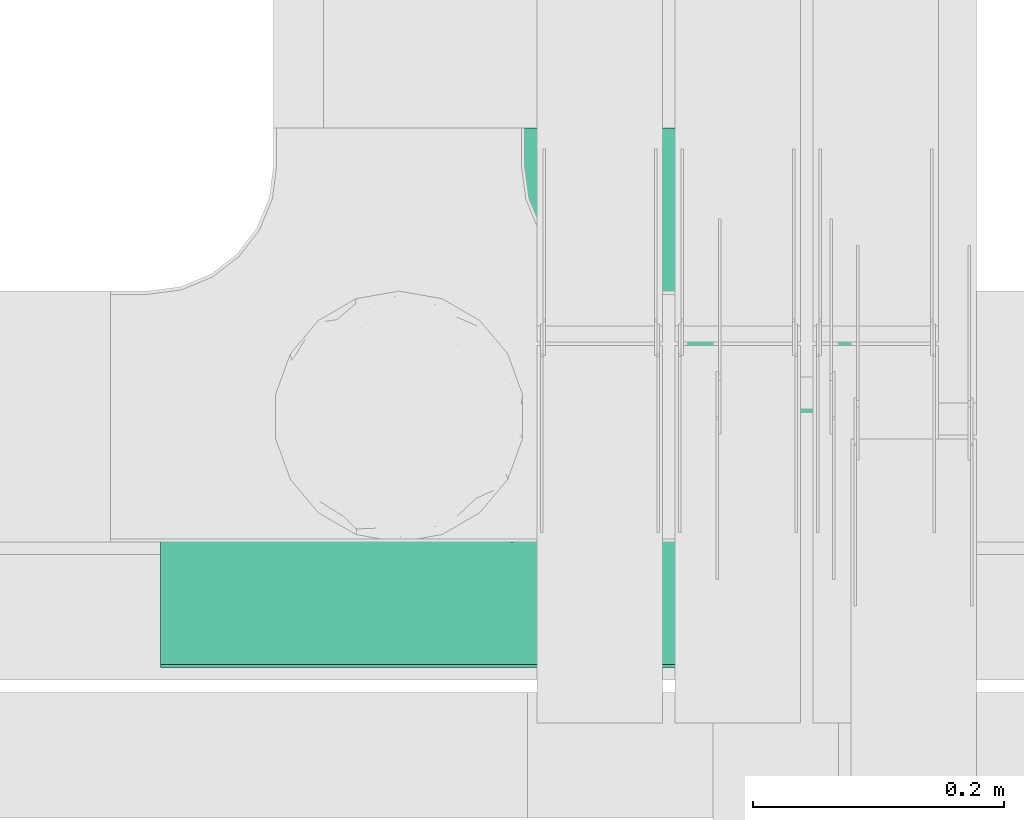
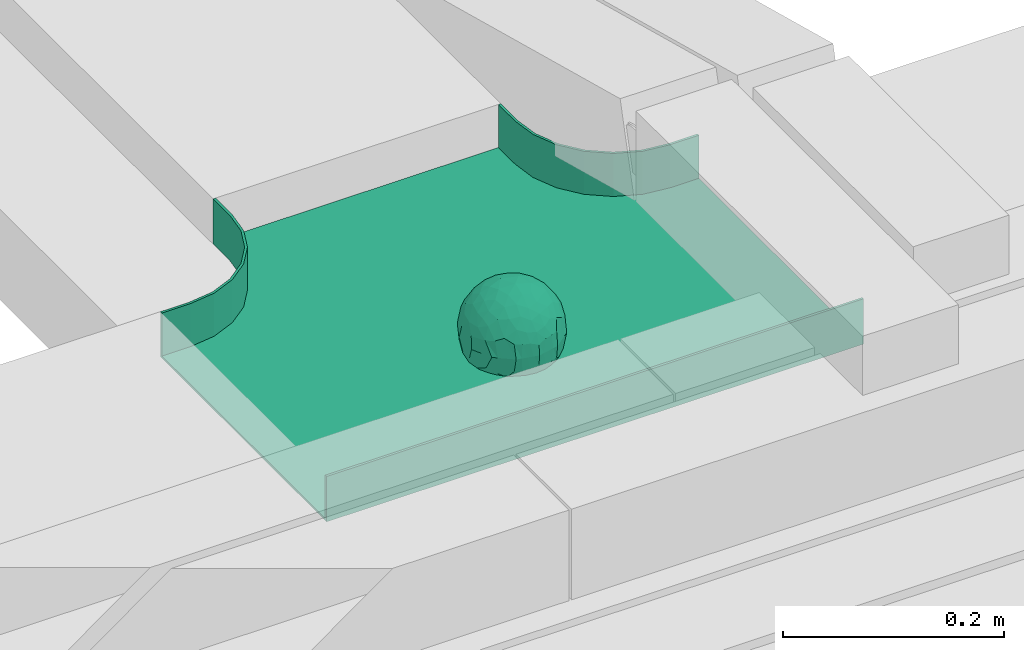
# One storey, part 32 of 32: 1 flow fitting.
"""IFC2X3 building model written with IfcOpenShell, lengths in millimetres."""

from ifc_helpers import new_model, entity, si_unit, converted_unit, derived_unit, direction, frame, origin, place, context, subcontext, project, spatial, faceted_brep, source, transform, mapped, material, material_list, type_object, type_shapes, element, save


model = new_model("IFC2X3")

# Units and contexts
model_context = context("Model", 3, precision=0.01, world=origin(), true_north=direction((6.12303176911189e-17, 1.0)))
body_context = subcontext(model_context, "Body", "Model", "MODEL_VIEW")
ifc_project = project(units=[si_unit("LENGTHUNIT", "METRE", prefix="MILLI"), si_unit("AREAUNIT", "SQUARE_METRE"), si_unit("VOLUMEUNIT", "CUBIC_METRE"), converted_unit("PLANEANGLEUNIT", "DEGREE", entity("IfcRatioMeasure", 0.0174532925199433), si_unit("PLANEANGLEUNIT", "RADIAN"), dimensions=[0, 0, 0, 0, 0, 0, 0]), si_unit("MASSUNIT", "GRAM", prefix="KILO"), derived_unit("MASSDENSITYUNIT", [(si_unit("MASSUNIT", "GRAM", prefix="KILO"), 1), (si_unit("LENGTHUNIT", "METRE"), -3)]), derived_unit("MOMENTOFINERTIAUNIT", [(si_unit("LENGTHUNIT", "METRE"), 4)]), si_unit("TIMEUNIT", "SECOND"), si_unit("FREQUENCYUNIT", "HERTZ"), si_unit("THERMODYNAMICTEMPERATUREUNIT", "DEGREE_CELSIUS"), derived_unit("THERMALTRANSMITTANCEUNIT", [(si_unit("MASSUNIT", "GRAM", prefix="KILO"), 1), (si_unit("THERMODYNAMICTEMPERATUREUNIT", "KELVIN"), -1), (si_unit("TIMEUNIT", "SECOND"), -3)]), derived_unit("VOLUMETRICFLOWRATEUNIT", [(si_unit("LENGTHUNIT", "METRE"), 3), (si_unit("TIMEUNIT", "SECOND"), -1)]), derived_unit("MASSFLOWRATEUNIT", [(si_unit("MASSUNIT", "GRAM", prefix="KILO"), 1), (si_unit("TIMEUNIT", "SECOND"), -1)]), derived_unit("ROTATIONALFREQUENCYUNIT", [(si_unit("TIMEUNIT", "SECOND"), -1)]), si_unit("ELECTRICCURRENTUNIT", "AMPERE"), si_unit("ELECTRICVOLTAGEUNIT", "VOLT"), si_unit("POWERUNIT", "WATT"), si_unit("FORCEUNIT", "NEWTON", prefix="KILO"), si_unit("ILLUMINANCEUNIT", "LUX"), si_unit("LUMINOUSFLUXUNIT", "LUMEN"), si_unit("LUMINOUSINTENSITYUNIT", "CANDELA"), derived_unit("USERDEFINED", [(si_unit("MASSUNIT", "GRAM", prefix="KILO"), -1), (si_unit("LENGTHUNIT", "METRE"), -2), (si_unit("TIMEUNIT", "SECOND"), 3), (si_unit("LUMINOUSFLUXUNIT", "LUMEN"), 1)]), derived_unit("LINEARVELOCITYUNIT", [(si_unit("LENGTHUNIT", "METRE"), 1), (si_unit("TIMEUNIT", "SECOND"), -1)]), si_unit("PRESSUREUNIT", "PASCAL"), derived_unit("USERDEFINED", [(si_unit("LENGTHUNIT", "METRE"), -2), (si_unit("MASSUNIT", "GRAM", prefix="KILO"), 1), (si_unit("TIMEUNIT", "SECOND"), -2)]), derived_unit("LINEARFORCEUNIT", [(si_unit("MASSUNIT", "GRAM", prefix="KILO"), 1), (si_unit("LENGTHUNIT", "METRE"), 1), (si_unit("TIMEUNIT", "SECOND"), -2), (si_unit("LENGTHUNIT", "METRE"), -1)]), derived_unit("PLANARFORCEUNIT", [(si_unit("MASSUNIT", "GRAM", prefix="KILO"), 1), (si_unit("LENGTHUNIT", "METRE"), 1), (si_unit("TIMEUNIT", "SECOND"), -2), (si_unit("LENGTHUNIT", "METRE"), -2)])], contexts=[model_context])

# Site, building, storey
site_placement = place(None, origin())
site = spatial("IfcSite", under=ifc_project, at=site_placement, CompositionType="ELEMENT")
building_placement = place(site_placement, origin())
building = spatial("IfcBuilding", under=site, at=building_placement, CompositionType="ELEMENT")
storey_placement = place(building_placement, frame((0.0, 0.0, 8100.0)))
storey = spatial("IfcBuildingStorey", under=building, at=storey_placement, CompositionType="ELEMENT", Elevation=8100.0)

# Flow fitting
ifc_material_1 = material()
ifc_material_2 = material()
ifc_material_list = material_list([ifc_material_1, ifc_material_2])
cable_carrier_fitting_type = type_object("IfcCableCarrierFittingType", PredefinedType="NOTDEFINED", material=ifc_material_1)
shared_shape = source(origin(), body_context, "Body", "Brep", [
    faceted_brep([(43.65, -13.62, -20.22), (44.77, 0.0, -22.26), (48.26, -5.6, -11.81), (16.66, 5.33, -46.84), (11.56, -8.33, -47.93), (2.02, 2.7, -49.89), (-7.81, -35.95, -33.86), (-17.21, -38.27, -27.19), (-11.13, -27.32, -40.37), (37.7, -7.25, -32.03), (10.64, 26.52, -41.03), (19.21, 19.84, -41.68), (10.42, 17.81, -45.54), (48.75, 0.0, 0.0), (48.07, 6.52, -12.13), (-37.46, 12.16, -30.81), (-31.35, 12.15, -37.01), (-38.09, 3.52, -32.2), (48.75, 11.13, 0.0), (9.67, 42.57, -24.39), (17.48, 37.97, -27.43), (8.35, 35.36, -34.35), (36.7, 20.43, -27.12), (28.22, 12.58, -39.31), (28.4, 24.01, -33.43), (37.1, 7.75, -32.61), (30.39, 38.11, 0.0), (34.74, 34.64, 0.0), (32.94, 32.13, -19.56), (26.04, 41.58, 0.0), (-44.77, 0.0, -22.26), (-35.92, -8.72, -33.67), (-42.7, -12.19, -22.99), (5.42, -48.76, 0.0), (0.0, -48.78, -10.96), (7.59, -47.43, -13.88), (34.0, -31.65, -18.51), (40.01, -26.24, -14.51), (30.39, -38.11, 0.0), (-47.55, -8.65, -12.8), (43.92, -21.15, 0.0), (-47.55, 8.68, -12.81), (-43.92, 21.15, 0.0), (-41.56, 23.54, -14.78), (-36.7, 20.43, -27.12), (-42.68, 12.16, -23.03), (-0.04, -44.68, -22.44), (43.35, 13.13, -21.19), (-9.67, -42.82, -23.94), (2.93, -38.3, -32.0), (10.58, -32.36, -36.62), (17.48, -37.97, -27.43), (29.42, -14.29, -37.82), (29.26, 0.0, -40.54), (-34.74, 34.64, 0.0), (-35.59, 30.87, -16.74), (16.27, 46.29, 0.0), (15.4, 45.37, -14.3), (10.85, 47.52, 0.0), (-22.09, 42.26, -15.04), (-16.27, 46.29, 0.0), (-15.4, 45.37, -14.3), (-35.57, -30.88, -16.76), (-34.74, -34.64, 0.0), (-41.54, -23.57, -14.78), (-21.2, -29.91, -34.0), (-22.09, -42.26, -15.04), (-28.59, -35.77, -20.07), (27.97, -26.92, -31.51), (26.56, -36.75, -21.06), (-4.7, -12.82, -48.1), (-3.71, -22.05, -44.72), (0.0, -29.85, -40.11), (-8.78, 23.47, -43.27), (-10.71, 12.15, -47.3), (-19.19, 19.81, -41.71), (19.21, -19.84, -41.68), (10.27, -43.25, -22.88), (-16.27, -46.29, 0.0), (-15.42, -45.43, -14.08), (-10.85, -47.52, 0.0), (-21.69, -45.05, 0.0), (-26.04, -41.58, 0.0), (-30.39, -38.11, 0.0), (-26.91, -11.71, -40.48), (-28.57, -22.53, -34.29), (-14.35, 0.55, -47.89), (20.39, 29.7, -34.67), (25.88, 35.56, -23.78), (-1.9, 38.3, -32.09), (-0.04, 44.68, -22.44), (-9.54, 42.67, -24.26), (-10.12, 33.04, -36.14), (-17.21, 38.27, -27.19), (-28.59, 35.77, -20.07), (-30.39, 38.11, 0.0), (-26.04, 41.58, 0.0), (-21.69, 45.05, 0.0), (0.92, 16.99, -47.01), (0.0, 29.85, -40.11), (-28.43, 23.64, -33.66), (22.08, -42.72, -13.7), (0.0, -50.0, 0.0), (-7.98, 47.29, -14.15), (-10.85, 47.52, 0.0), (-5.42, 48.76, 0.0), (-39.09, -31.17, 0.0), (-36.7, -20.43, -27.12), (-20.05, 29.88, -34.71), (48.75, -11.13, 0.0), (36.7, -20.43, -27.12), (39.09, -31.17, 0.0), (43.92, 21.15, 0.0), (41.04, 24.48, -14.72), (21.43, -9.87, -44.08), (19.85, -30.3, -34.47), (26.04, -41.58, 0.0), (8.28, -22.62, -43.82), (-19.19, -19.81, -41.71), (-17.56, -9.66, -45.81), (-29.26, 0.0, -40.54), (-22.28, 8.45, -43.96), (21.69, -45.05, 0.0), (-7.75, -47.32, -14.15), (22.09, 42.36, -14.75), (21.69, 45.05, 0.0), (7.94, 47.25, -14.29), (5.42, 48.76, 0.0), (-43.92, -21.15, 0.0), (-39.09, 31.17, 0.0), (-48.75, 11.13, 0.0), (-48.75, -11.13, 0.0), (-48.75, 0.0, 0.0), (0.0, 50.0, 0.0), (0.0, 48.77, -11.04), (-5.42, -48.76, 0.0), (16.27, -46.29, 0.0), (10.85, -47.52, 0.0), (39.09, 31.17, 0.0), (34.74, -34.64, 0.0), (-43.65, -13.62, 20.22), (-44.77, 0.0, 22.26), (-48.26, -5.6, 11.81), (-16.66, 5.33, 46.84), (-11.56, -8.33, 47.93), (-2.02, 2.7, 49.89), (7.81, -35.95, 33.86), (17.21, -38.27, 27.19), (11.13, -27.32, 40.37), (-37.7, -7.25, 32.03), (-10.64, 26.52, 41.03), (-19.21, 19.84, 41.68), (-10.42, 17.81, 45.54), (-48.07, 6.52, 12.13), (37.46, 12.16, 30.81), (31.35, 12.15, 37.01), (38.09, 3.52, 32.2), (-9.67, 42.57, 24.39), (-17.48, 37.97, 27.43), (-8.35, 35.36, 34.35), (-36.7, 20.43, 27.12), (-28.22, 12.58, 39.31), (-28.4, 24.01, 33.43), (-37.1, 7.75, 32.61), (-32.94, 32.13, 19.56), (44.77, 0.0, 22.26), (35.92, -8.72, 33.67), (42.7, -12.19, 22.99), (0.0, -48.78, 10.96), (-7.59, -47.43, 13.88), (-34.0, -31.65, 18.51), (-40.01, -26.24, 14.51), (47.55, -8.65, 12.8), (47.55, 8.68, 12.81), (41.56, 23.54, 14.78), (36.7, 20.43, 27.12), (42.68, 12.16, 23.03), (0.04, -44.68, 22.44), (-43.35, 13.13, 21.19), (9.67, -42.82, 23.94), (-2.93, -38.3, 32.0), (-10.58, -32.36, 36.62), (-17.48, -37.97, 27.43), (-29.42, -14.29, 37.82), (-29.26, 0.0, 40.54), (35.59, 30.87, 16.74), (-15.4, 45.37, 14.3), (22.09, 42.26, 15.04), (15.4, 45.37, 14.3), (35.57, -30.88, 16.76), (41.54, -23.57, 14.78), (21.2, -29.91, 34.0), (22.09, -42.26, 15.04), (28.59, -35.77, 20.07), (-27.97, -26.92, 31.51), (-26.56, -36.75, 21.06), (4.7, -12.82, 48.1), (3.71, -22.05, 44.72), (0.0, -29.85, 40.11), (8.78, 23.47, 43.27), (10.71, 12.15, 47.3), (19.19, 19.81, 41.71), (-19.21, -19.84, 41.68), (-10.27, -43.25, 22.88), (15.42, -45.43, 14.08), (26.91, -11.71, 40.48), (28.57, -22.53, 34.29), (14.35, 0.55, 47.89), (-20.39, 29.7, 34.67), (-25.88, 35.56, 23.78), (1.9, 38.3, 32.09), (0.04, 44.68, 22.44), (9.54, 42.67, 24.26), (10.12, 33.04, 36.14), (17.21, 38.27, 27.19), (28.59, 35.77, 20.07), (-0.92, 16.99, 47.01), (0.0, 29.85, 40.11), (28.43, 23.64, 33.66), (-22.08, -42.72, 13.7), (7.98, 47.29, 14.15), (36.7, -20.43, 27.12), (20.05, 29.88, 34.71), (-36.7, -20.43, 27.12), (-41.04, 24.48, 14.72), (-21.43, -9.87, 44.08), (-19.85, -30.3, 34.47), (-8.28, -22.62, 43.82), (19.19, -19.81, 41.71), (17.56, -9.66, 45.81), (29.26, 0.0, 40.54), (22.28, 8.45, 43.96), (7.75, -47.32, 14.15), (-22.09, 42.36, 14.75), (-7.94, 47.25, 14.29), (0.0, 48.77, 11.04)], [[[0, 1, 2]], [[3, 4, 5]], [[6, 7, 8]], [[1, 0, 9]], [[10, 11, 12]], [[13, 2, 14]], [[15, 16, 17]], [[14, 18, 13]], [[19, 20, 21]], [[22, 23, 24]], [[1, 9, 25]], [[26, 27, 28, 29]], [[30, 31, 32]], [[33, 34, 35]], [[36, 37, 38]], [[32, 39, 30]], [[2, 40, 0]], [[23, 22, 25]], [[41, 42, 43]], [[44, 15, 45]], [[46, 35, 34]], [[25, 22, 47]], [[31, 30, 17]], [[48, 49, 46]], [[50, 51, 49]], [[52, 53, 9]], [[43, 54, 55]], [[56, 57, 58]], [[59, 60, 61]], [[62, 63, 64]], [[8, 7, 65]], [[7, 66, 67]], [[68, 36, 69]], [[70, 5, 4]], [[8, 71, 72]], [[73, 74, 75]], [[68, 76, 52]], [[77, 46, 49]], [[78, 79, 80]], [[7, 6, 48]], [[67, 81, 82, 83]], [[84, 85, 31]], [[85, 65, 67]], [[70, 86, 5]], [[23, 3, 11]], [[21, 87, 10]], [[21, 20, 87]], [[28, 24, 88]], [[19, 89, 90]], [[91, 90, 89]], [[91, 92, 93]], [[94, 95, 96, 97]], [[98, 99, 10]], [[100, 16, 44]], [[77, 51, 101]], [[33, 102, 34]], [[103, 91, 61]], [[93, 59, 61]], [[104, 105, 103]], [[106, 64, 63]], [[107, 31, 85]], [[100, 94, 108]], [[108, 93, 92]], [[43, 55, 44]], [[0, 40, 37]], [[2, 13, 109]], [[2, 1, 14]], [[110, 9, 0]], [[2, 109, 40]], [[37, 40, 111]], [[47, 14, 1]], [[112, 14, 47]], [[113, 112, 47]], [[112, 18, 14]], [[47, 22, 113]], [[52, 9, 110]], [[53, 25, 9]], [[25, 47, 1]], [[23, 25, 53]], [[68, 52, 110]], [[76, 4, 114]], [[51, 115, 69]], [[50, 115, 51]], [[110, 36, 68]], [[3, 23, 53]], [[23, 11, 24]], [[52, 76, 114]], [[98, 12, 5]], [[11, 87, 24]], [[24, 28, 22]], [[87, 88, 24]], [[36, 116, 69]], [[28, 27, 113]], [[114, 3, 53]], [[76, 115, 117]], [[70, 4, 117]], [[118, 84, 119]], [[119, 70, 118]], [[120, 16, 121]], [[37, 36, 110]], [[116, 36, 38]], [[116, 122, 69]], [[34, 123, 46]], [[10, 87, 11]], [[87, 20, 88]], [[12, 98, 10]], [[10, 99, 21]], [[74, 5, 86]], [[73, 75, 108]], [[124, 56, 125]], [[124, 29, 88]], [[89, 21, 99]], [[21, 89, 19]], [[92, 89, 99]], [[89, 92, 91]], [[126, 127, 58]], [[88, 29, 28]], [[20, 57, 124]], [[88, 20, 124]], [[57, 20, 19]], [[73, 92, 99]], [[92, 73, 108]], [[99, 98, 73]], [[74, 86, 121]], [[73, 98, 74]], [[5, 74, 98]], [[100, 108, 75]], [[94, 93, 108]], [[86, 120, 121]], [[100, 44, 55]], [[75, 16, 100]], [[17, 16, 120]], [[31, 17, 120]], [[17, 30, 45]], [[84, 31, 120]], [[31, 107, 32]], [[41, 45, 30]], [[43, 44, 45]], [[107, 64, 32]], [[39, 64, 128]], [[30, 39, 41]], [[129, 43, 42]], [[41, 130, 42]], [[43, 45, 41]], [[62, 83, 63]], [[95, 94, 55]], [[100, 55, 94]], [[64, 107, 62]], [[131, 39, 128]], [[64, 106, 128]], [[85, 62, 107]], [[67, 83, 62]], [[39, 32, 64]], [[130, 41, 132]], [[59, 97, 60]], [[133, 127, 134]], [[59, 94, 97]], [[104, 61, 60]], [[94, 59, 93]], [[126, 134, 127]], [[126, 58, 57]], [[19, 90, 126]], [[134, 105, 133]], [[126, 90, 134]], [[103, 90, 91]], [[105, 134, 103]], [[90, 103, 134]], [[119, 120, 86]], [[84, 118, 85]], [[65, 85, 118]], [[62, 85, 67]], [[8, 65, 118]], [[67, 65, 7]], [[71, 118, 70]], [[8, 72, 6]], [[49, 6, 72]], [[6, 49, 48]], [[50, 49, 72]], [[77, 49, 51]], [[101, 69, 122]], [[123, 34, 135]], [[101, 122, 136]], [[137, 77, 136]], [[78, 81, 66]], [[7, 79, 66]], [[67, 66, 81]], [[79, 7, 48]], [[35, 137, 33]], [[123, 80, 79]], [[135, 34, 102]], [[35, 46, 77]], [[80, 123, 135]], [[46, 123, 48]], [[117, 50, 72]], [[115, 76, 68]], [[117, 72, 71]], [[4, 76, 117]], [[39, 132, 41]], [[39, 131, 132]], [[137, 35, 77]], [[124, 57, 56]], [[126, 57, 19]], [[103, 61, 104]], [[61, 91, 93]], [[77, 101, 136]], [[51, 69, 101]], [[28, 113, 22]], [[112, 113, 138]], [[16, 75, 121]], [[74, 121, 75]], [[66, 79, 78]], [[123, 79, 48]], [[0, 37, 110]], [[37, 111, 139, 38]], [[29, 124, 125]], [[115, 50, 117]], [[69, 115, 68]], [[120, 119, 84]], [[70, 119, 86]], [[11, 3, 12]], [[5, 12, 3]], [[118, 71, 8]], [[117, 71, 70]], [[3, 114, 4]], [[53, 52, 114]], [[27, 138, 113]], [[45, 15, 17]], [[44, 16, 15]], [[55, 54, 95]], [[43, 129, 54]], [[140, 141, 142]], [[143, 144, 145]], [[146, 147, 148]], [[141, 140, 149]], [[150, 151, 152]], [[132, 142, 153]], [[154, 155, 156]], [[153, 130, 132]], [[157, 158, 159]], [[160, 161, 162]], [[141, 149, 163]], [[95, 54, 164, 96]], [[165, 166, 167]], [[135, 168, 169]], [[170, 171, 83]], [[167, 172, 165]], [[142, 141, 153]], [[161, 160, 163]], [[173, 112, 174]], [[175, 154, 176]], [[177, 169, 168]], [[163, 160, 178]], [[166, 165, 156]], [[179, 180, 177]], [[181, 182, 180]], [[183, 184, 149]], [[174, 27, 185]], [[60, 186, 104]], [[187, 56, 188]], [[189, 139, 190]], [[148, 147, 191]], [[147, 192, 193]], [[194, 170, 195]], [[196, 145, 144]], [[148, 197, 198]], [[199, 200, 201]], [[194, 202, 183]], [[203, 177, 180]], [[136, 204, 137]], [[147, 146, 179]], [[193, 122, 116, 38]], [[205, 206, 166]], [[206, 191, 193]], [[196, 207, 145]], [[161, 143, 151]], [[159, 208, 150]], [[159, 158, 208]], [[164, 162, 209]], [[157, 210, 211]], [[212, 211, 210]], [[212, 213, 214]], [[215, 26, 29, 125]], [[216, 217, 150]], [[218, 155, 175]], [[203, 182, 219]], [[135, 102, 168]], [[220, 212, 188]], [[214, 187, 188]], [[58, 127, 220]], [[111, 190, 139]], [[221, 166, 206]], [[218, 215, 222]], [[222, 214, 213]], [[174, 185, 175]], [[171, 140, 128]], [[132, 131, 142]], [[142, 128, 140]], [[223, 149, 140]], [[142, 131, 128]], [[171, 128, 106]], [[178, 153, 141]], [[42, 153, 178]], [[224, 42, 178]], [[42, 130, 153]], [[178, 160, 224]], [[183, 149, 223]], [[184, 163, 149]], [[163, 178, 141]], [[161, 163, 184]], [[194, 183, 223]], [[202, 144, 225]], [[182, 226, 195]], [[181, 226, 182]], [[223, 170, 194]], [[143, 161, 184]], [[161, 151, 162]], [[183, 202, 225]], [[216, 152, 145]], [[151, 208, 162]], [[162, 164, 160]], [[208, 209, 162]], [[170, 82, 195]], [[164, 54, 224]], [[225, 143, 184]], [[202, 226, 227]], [[196, 144, 227]], [[228, 205, 229]], [[229, 196, 228]], [[230, 155, 231]], [[171, 170, 223]], [[82, 170, 83]], [[82, 81, 195]], [[168, 232, 177]], [[150, 208, 151]], [[208, 158, 209]], [[152, 216, 150]], [[150, 217, 159]], [[200, 145, 207]], [[199, 201, 222]], [[233, 60, 97]], [[233, 96, 209]], [[210, 159, 217]], [[159, 210, 157]], [[213, 210, 217]], [[210, 213, 212]], [[234, 105, 104]], [[209, 96, 164]], [[158, 186, 233]], [[209, 158, 233]], [[186, 158, 157]], [[199, 213, 217]], [[213, 199, 222]], [[217, 216, 199]], [[200, 207, 231]], [[199, 216, 200]], [[145, 200, 216]], [[218, 222, 201]], [[215, 214, 222]], [[207, 230, 231]], [[218, 175, 185]], [[201, 155, 218]], [[156, 155, 230]], [[166, 156, 230]], [[156, 165, 176]], [[205, 166, 230]], [[166, 221, 167]], [[173, 176, 165]], [[174, 175, 176]], [[221, 190, 167]], [[172, 190, 40]], [[165, 172, 173]], [[138, 174, 112]], [[173, 18, 112]], [[174, 176, 173]], [[189, 38, 139]], [[26, 215, 185]], [[218, 185, 215]], [[190, 221, 189]], [[109, 172, 40]], [[190, 111, 40]], [[206, 189, 221]], [[193, 38, 189]], [[172, 167, 190]], [[18, 173, 13]], [[187, 125, 56]], [[133, 105, 235]], [[187, 215, 125]], [[58, 188, 56]], [[215, 187, 214]], [[234, 235, 105]], [[234, 104, 186]], [[157, 211, 234]], [[235, 127, 133]], [[234, 211, 235]], [[220, 211, 212]], [[127, 235, 220]], [[211, 220, 235]], [[229, 230, 207]], [[205, 228, 206]], [[191, 206, 228]], [[189, 206, 193]], [[148, 191, 228]], [[193, 191, 147]], [[197, 228, 196]], [[148, 198, 146]], [[180, 146, 198]], [[146, 180, 179]], [[181, 180, 198]], [[203, 180, 182]], [[219, 195, 81]], [[232, 168, 33]], [[219, 81, 78]], [[80, 203, 78]], [[136, 122, 192]], [[147, 204, 192]], [[193, 192, 122]], [[204, 147, 179]], [[169, 80, 135]], [[232, 137, 204]], [[33, 168, 102]], [[169, 177, 203]], [[137, 232, 33]], [[177, 232, 179]], [[227, 181, 198]], [[226, 202, 194]], [[227, 198, 197]], [[144, 202, 227]], [[172, 13, 173]], [[172, 109, 13]], [[80, 169, 203]], [[233, 186, 60]], [[234, 186, 157]], [[220, 188, 58]], [[188, 212, 214]], [[203, 219, 78]], [[182, 195, 219]], [[164, 224, 160]], [[42, 224, 129]], [[155, 201, 231]], [[200, 231, 201]], [[192, 204, 136]], [[232, 204, 179]], [[140, 171, 223]], [[171, 106, 63, 83]], [[96, 233, 97]], [[226, 181, 227]], [[195, 226, 194]], [[230, 229, 205]], [[196, 229, 207]], [[151, 143, 152]], [[145, 152, 143]], [[228, 197, 148]], [[227, 197, 196]], [[143, 225, 144]], [[184, 183, 225]], [[54, 129, 224]], [[176, 154, 156]], [[175, 155, 154]], [[185, 27, 26]], [[174, 138, 27]]]),
    faceted_brep([(280.0, -150.0, 25.0), (280.0, -147.46, 25.0), (250.0, -147.46, 25.0), (223.46, -150.95, 25.0), (198.73, -161.2, 25.0), (177.49, -177.49, 25.0), (161.2, -198.73, 25.0), (150.95, -223.46, 25.0), (147.46, -250.0, 25.0), (147.46, -280.0, 25.0), (150.0, -280.0, 25.0), (150.0, -250.0, 25.0), (153.41, -224.12, 25.0), (163.4, -200.0, 25.0), (179.29, -179.29, 25.0), (200.0, -163.4, 25.0), (224.12, -153.41, 25.0), (250.0, -150.0, 25.0), (-153.41, -224.12, 25.0), (-150.0, -250.0, 25.0), (-150.0, -280.0, 25.0), (-147.46, -280.0, 25.0), (-147.46, -250.0, 25.0), (-150.95, -223.46, 25.0), (-161.2, -198.73, 25.0), (-177.49, -177.49, 25.0), (-198.73, -161.2, 25.0), (-223.46, -150.95, 25.0), (-250.0, -147.46, 25.0), (-280.0, -147.46, 25.0), (-280.0, -150.0, 25.0), (-250.0, -150.0, 25.0), (-224.12, -153.41, 25.0), (-200.0, -163.4, 25.0), (-179.29, -179.29, 25.0), (-163.4, -200.0, 25.0), (280.0, 147.46, 25.0), (280.0, 150.0, 25.0), (-280.0, 150.0, 25.0), (-280.0, 147.46, 25.0), (-280.0, -150.0, -25.0), (-280.0, 150.0, -25.0), (280.0, 150.0, -25.0), (280.0, -150.0, -25.0), (250.0, -150.0, -25.0), (224.12, -153.41, -25.0), (200.0, -163.4, -25.0), (179.29, -179.29, -25.0), (163.4, -200.0, -25.0), (153.41, -224.12, -25.0), (150.0, -250.0, -25.0), (150.0, -280.0, -25.0), (-150.0, -280.0, -25.0), (-150.0, -250.0, -25.0), (-153.41, -224.12, -25.0), (-163.4, -200.0, -25.0), (-179.29, -179.29, -25.0), (-200.0, -163.4, -25.0), (-224.12, -153.41, -25.0), (-250.0, -150.0, -25.0), (-150.0, -250.0, -22.46), (147.46, -280.0, -22.46), (-147.46, -280.0, -22.46), (-147.46, -250.0, -22.46), (-250.0, -147.46, -22.46), (-280.0, -147.46, -22.46), (280.0, -147.46, -22.46), (250.0, -147.46, -22.46), (-280.0, 147.46, -22.46), (-250.0, -150.0, -22.46), (250.0, -150.0, -22.46), (280.0, 147.46, -22.46), (147.46, -250.0, -22.46), (150.0, -250.0, -22.46), (-223.46, -150.95, -22.46), (-198.73, -161.2, -22.46), (-177.49, -177.49, -22.46), (-161.2, -198.73, -22.46), (-150.95, -223.46, -22.46), (150.95, -223.46, -22.46), (161.2, -198.73, -22.46), (177.49, -177.49, -22.46), (198.73, -161.2, -22.46), (223.46, -150.95, -22.46)], [[[0, 1, 2, 3, 4, 5, 6, 7, 8, 9, 10, 11, 12, 13, 14, 15, 16, 17]], [[18, 19, 20, 21, 22, 23, 24, 25, 26, 27, 28, 29, 30, 31, 32, 33, 34, 35]], [[36, 37, 38, 39]], [[40, 41, 42, 43, 44, 45, 46, 47, 48, 49, 50, 51, 52, 53, 54, 55, 56, 57, 58, 59]], [[20, 19, 60, 53, 52]], [[21, 20, 52, 51, 10, 9, 61, 62]], [[22, 21, 62, 63]], [[29, 28, 64, 65]], [[2, 1, 66, 67]], [[39, 38, 41, 40, 30, 29, 65, 68]], [[31, 30, 40, 59, 69]], [[0, 17, 70, 44, 43]], [[1, 0, 43, 42, 37, 36, 71, 66]], [[9, 8, 72, 61]], [[11, 10, 51, 50, 73]], [[38, 37, 42, 41]], [[36, 39, 68, 71]], [[68, 65, 64, 74, 75, 76, 77, 78, 63, 62, 61, 72, 79, 80, 81, 82, 83, 67, 66, 71]], [[32, 31, 69, 59, 58]], [[58, 57, 33, 32]], [[33, 57, 56, 34]], [[18, 35, 55, 54]], [[18, 54, 53, 60, 19]], [[55, 35, 34, 56]], [[23, 22, 63, 78]], [[24, 23, 78, 77]], [[25, 24, 77, 76]], [[26, 25, 76, 75]], [[27, 26, 75, 74]], [[28, 27, 74, 64]], [[3, 2, 67, 83]], [[4, 3, 83, 82]], [[5, 4, 82, 81]], [[6, 5, 81, 80]], [[7, 6, 80, 79]], [[72, 8, 7, 79]], [[12, 11, 73, 50, 49]], [[13, 12, 49, 48]], [[13, 48, 47, 14]], [[15, 14, 47, 46]], [[45, 16, 15, 46]], [[16, 45, 44, 70, 17]]]),
])
type_shapes(cable_carrier_fitting_type, [shared_shape])
flow_fitting_placement = place(storey_placement, frame((60450.11, 9019.98, 2813.92), z_axis=(0.0, 0.0, 1.0), x_axis=(-1.0, 0.0, 0.0)))
element("IfcFlowFitting", 1, at=flow_fitting_placement, inside=storey, type_object=cable_carrier_fitting_type, material=ifc_material_list, Name="470_DKC_S5_T", context=body_context, shape_type="MappedRepresentation", body=[
    mapped(shared_shape, transform((0.0, 0.0, 0.0), scale=1.0)),
])

save(model, "model.ifc")
